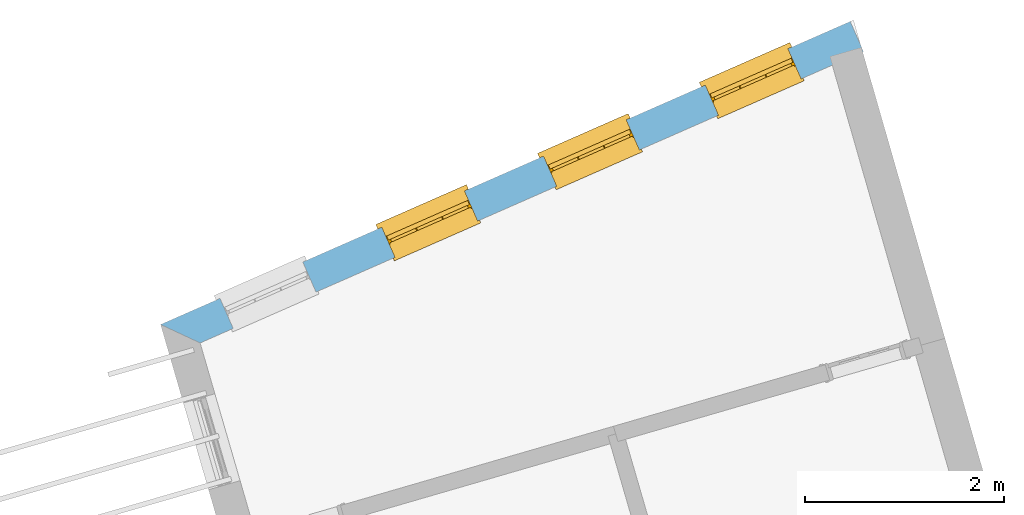
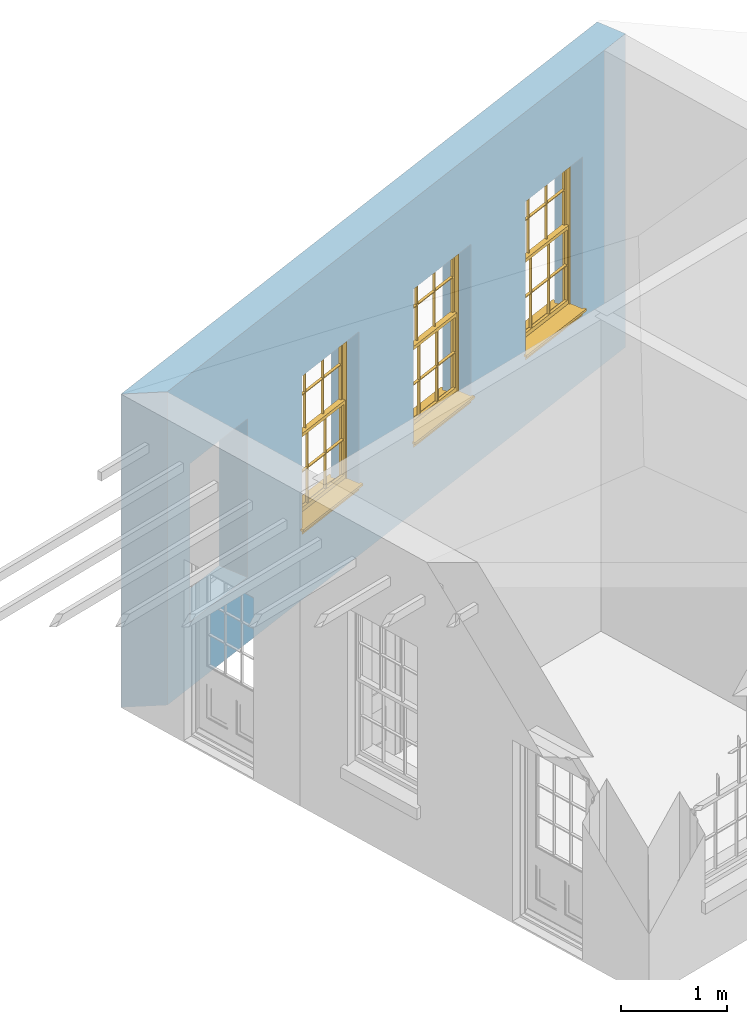
# One storey, part 6 of 10: 3 windows, 4 openings, plus 1 element that does not belong to this part.
"""IFC2X3 building model written with IfcOpenShell, lengths in metres."""

from ifc_helpers import new_model, si_unit, frame, origin, place, context, subcontext, project, spatial, polyline, outline, extrude, faceted_brep, material, layer, layer_set, layer_usage, element, fill, save


model = new_model("IFC2X3")

# Units and contexts
model_context = context("Model", 3, world=origin())
body_context = subcontext(model_context, "Body", "Model", "MODEL_VIEW")
ifc_project = project(units=[si_unit("PLANEANGLEUNIT", "RADIAN"), si_unit("MASSUNIT", "GRAM", prefix="KILO"), si_unit("FORCEUNIT", "NEWTON", prefix="KILO"), si_unit("LENGTHUNIT", "METRE")], contexts=[model_context])

# Site, building, storey
site_placement = place(None, origin())
site = spatial("IfcSite", under=ifc_project, at=site_placement, CompositionType="ELEMENT")
building_placement = place(None, origin())
building = spatial("IfcBuilding", under=site, at=building_placement, Name="Building plot-15", CompositionType="ELEMENT")
storey_placement = place(None, frame((0.0, 0.0, 11.05)))
storey = spatial("IfcBuildingStorey", under=building, at=storey_placement, Name="Floor 2", CompositionType="ELEMENT", Elevation=11.05)

# Wall, openings, windows
ifc_material = material(Name="Masonry")
ifc_layer = layer(ifc_material, 0.33, ventilated=False)
ifc_layer_set = layer_set([ifc_layer], Name="My Wall")
ifc_layer_usage = layer_usage(ifc_layer_set, "AXIS2", "NEGATIVE", 0.08)
wall_placement = place(storey_placement, origin())
wall = element("IfcWallStandardCase", 1, at=wall_placement, inside=storey, material=ifc_layer_usage, Name="exterior", context=body_context, shape_type="SweptSolid", body=[
    extrude(outline(polyline([(95.6723187451732, 60.4106615143609), (95.5395561949644, 60.7127775603797), (88.6036069877965, 57.6648285454347), (89.0011789339124, 57.4790809319541), (95.6723187451732, 60.4106615143609)])), origin(), (0.0, 0.0, 1.0), 3.6),
])
opening_1_placement = place(storey_placement, frame((0.0, 0.0, 0.75)))
opening_1 = element("IfcOpeningElement", 2, at=opening_1_placement, cuts=wall, Name="Opening", ObjectType="Opening", context=body_context, shape_type="SweptSolid", body=[
    extrude(outline(polyline([(94.9139268152625, 60.4378495880681), (94.0808189307863, 60.0717467980984), (94.2135814809951, 59.7696307520796), (95.0466893654713, 60.1357335420493), (94.9139268152625, 60.4378495880681)])), origin(), (0.0, 0.0, 1.0), 1.82),
])
opening_2_placement = place(storey_placement, frame((0.0, 0.0, 0.75)))
opening_2 = element("IfcOpeningElement", 3, at=opening_2_placement, cuts=wall, Name="Opening", ObjectType="Opening", context=body_context, shape_type="SweptSolid", body=[
    extrude(outline(polyline([(93.2873117562595, 59.7230462325794), (92.4542038717833, 59.3569434426097), (92.5869664219921, 59.0548273965908), (93.4200743064683, 59.4209301865605), (93.2873117562595, 59.7230462325794)])), origin(), (0.0, 0.0, 1.0), 1.82),
])
opening_3_placement = place(storey_placement, frame((0.0, 0.0, 0.75)))
opening_3 = element("IfcOpeningElement", 4, at=opening_3_placement, cuts=wall, Name="Opening", ObjectType="Opening", context=body_context, shape_type="SweptSolid", body=[
    extrude(outline(polyline([(91.6606966972566, 59.0082428770907), (90.8275888127803, 58.642140087121), (90.9603513629891, 58.3400240411021), (91.7934592474653, 58.7061268310718), (91.6606966972566, 59.0082428770907)])), origin(), (0.0, 0.0, 1.0), 1.82),
])
opening_4_placement = place(storey_placement, frame((0.0, 0.0, 0.75)))
element("IfcOpeningElement", 5, at=opening_4_placement, cuts=wall, Name="Opening", ObjectType="Opening", context=body_context, shape_type="SweptSolid", body=[
    extrude(outline(polyline([(90.0340816382536, 58.2934395216019), (89.2009737537774, 57.9273367316322), (89.3337363039862, 57.6252206856134), (90.1668441884623, 57.9913234755831), (90.0340816382536, 58.2934395216019)])), origin(), (0.0, 0.0, 1.0), 1.82),
])
window_1_placement = place(storey_placement, frame((95.0145045048146, 60.2089737956296, 0.75), z_axis=(0.0, 0.0, 1.0), x_axis=(-0.833107884476192, -0.366102789969688, 0.0)))
window_1 = element("IfcWindow", 6, at=window_1_placement, inside=storey, Name="circulation outside window", OverallHeight=1.82, OverallWidth=0.91, context=body_context, shape_type="Brep", held_by="IfcProductRepresentation", body=[
    faceted_brep([(0.033125, -0.105, 0.975209), (0.01, -0.105, 0.975209), (0.033125, -0.105, 1.376042), (0.876875, -0.105, 0.975209), (0.876875, -0.105, 1.376042), (0.9, -0.105, 0.975209), (0.876875, -0.105, 1.386042), (0.876875, -0.105, 1.786875), (0.9, -0.105, 1.81), (0.033125, -0.105, 1.786875), (0.033125, -0.105, 1.386042), (0.01, -0.105, 1.81), (0.876875, -0.135, 1.376042), (0.876875, -0.135, 0.975209), (0.9, -0.135, 0.937083), (0.033125, -0.135, 1.786875), (0.01, -0.135, 1.81), (0.033125, -0.135, 1.386042), (0.01, -0.135, 0.937083), (0.033125, -0.135, 0.975209), (0.033125, -0.135, 1.376042), (0.876875, -0.135, 1.786875), (0.876875, -0.135, 1.386042), (0.9, -0.135, 1.81), (0.033125, -0.105, 0.937083), (0.01, -0.105, 0.937083), (0.033125, -0.105, 0.53625), (0.876875, -0.105, 0.937083), (0.876875, -0.105, 0.53625), (0.9, -0.105, 0.937083), (0.876875, -0.105, 0.52625), (0.876875, -0.105, 0.125417), (0.9, -0.105, 0.077167), (0.033125, -0.105, 0.125417), (0.033125, -0.105, 0.52625), (0.01, -0.105, 0.077167), (-0.0425, -0.25, 0.01), (-0.0425, -0.3, 0.001667), (0.0, -0.25, 0.01), (0.9525, -0.25, 0.01), (0.91, -0.25, 0.01), (0.9525, -0.3, 0.001667), (-0.02, 0.08, 0.077167), (0.0, 0.08, 0.077167), (-0.02, 0.11, 0.077167), (0.0, -0.06, 0.077167), (0.01, -0.06, 0.077167), (0.91, -0.06, 0.077167), (0.91, 0.08, 0.077167), (0.9, -0.06, 0.077167), (0.93, 0.08, 0.077167), (0.93, 0.11, 0.077167), (0.01, -0.075, 0.975209), (0.9, -0.075, 0.975209), (0.876875, -0.075, 0.125417), (0.876875, -0.075, 0.52625), (0.9, -0.075, 0.077167), (0.876875, -0.075, 0.53625), (0.876875, -0.075, 0.937083), (0.033125, -0.075, 0.125417), (0.01, -0.075, 0.077167), (0.033125, -0.075, 0.52625), (0.033125, -0.075, 0.937083), (0.033125, -0.075, 0.53625), (-0.02, 0.08, 0.052167), (-0.02, 0.11, 0.052167), (0.93, 0.11, 0.052167), (0.93, 0.08, 0.052167), (0.91, 0.08, 0.052167), (0.0, 0.08, 0.052167), (0.91, -0.15, 0.026667), (0.0, -0.15, 0.026667), (-0.0425, -0.3, -0.123333), (0.9525, -0.3, -0.123333), (-0.0425, -0.25, -0.123333), (0.9525, -0.25, -0.123333), (0.01, -0.06, 1.81), (0.9, -0.06, 1.81), (0.0, -0.06, 1.82), (0.91, -0.06, 1.82), (0.01, -0.15, 0.077167), (0.9, -0.15, 0.077167), (0.592292, -0.105, 0.125417), (0.592292, -0.075, 0.125417), (0.317708, -0.075, 0.125417), (0.317708, -0.105, 0.125417), (0.592292, -0.105, 0.53625), (0.317708, -0.105, 0.53625), (0.317708, -0.105, 0.52625), (0.592292, -0.105, 0.52625), (0.592292, -0.075, 0.53625), (0.317708, -0.075, 0.53625), (0.592292, -0.135, 1.386042), (0.592292, -0.105, 1.386042), (0.317708, -0.105, 1.386042), (0.317708, -0.135, 1.386042), (0.317708, -0.135, 1.376042), (0.592292, -0.135, 1.376042), (0.317708, -0.105, 1.376042), (0.592292, -0.105, 1.376042), (0.602292, -0.135, 1.376042), (0.592292, -0.135, 0.975209), (0.602292, -0.135, 0.975209), (0.602292, -0.105, 0.975209), (0.592292, -0.105, 0.975209), (0.602292, -0.105, 1.376042), (0.602292, -0.075, 0.53625), (0.602292, -0.105, 0.53625), (0.317708, -0.075, 0.52625), (0.307708, -0.075, 0.125417), (0.307708, -0.075, 0.52625), (0.602292, -0.075, 0.52625), (0.602292, -0.075, 0.125417), (0.592292, -0.075, 0.52625), (0.307708, -0.075, 0.53625), (0.317708, -0.075, 0.937083), (0.307708, -0.075, 0.937083), (0.602292, -0.075, 0.937083), (0.592292, -0.075, 0.937083), (0.307708, -0.105, 0.52625), (0.307708, -0.105, 0.125417), (0.307708, -0.105, 0.53625), (0.307708, -0.105, 0.937083), (0.592292, -0.105, 0.937083), (0.317708, -0.105, 0.937083), (0.602292, -0.105, 0.937083), (0.602292, -0.105, 0.52625), (0.602292, -0.105, 0.125417), (0.307708, -0.135, 1.386042), (0.307708, -0.135, 1.376042), (0.307708, -0.135, 0.975209), (0.317708, -0.135, 0.975209), (0.317708, -0.135, 1.786875), (0.307708, -0.135, 1.786875), (0.602292, -0.135, 1.786875), (0.592292, -0.135, 1.786875), (0.602292, -0.135, 1.386042), (0.602292, -0.105, 1.386042), (0.307708, -0.105, 1.386042), (0.307708, -0.105, 1.786875), (0.317708, -0.105, 1.786875), (0.592292, -0.105, 1.786875), (0.602292, -0.105, 1.786875), (0.307708, -0.105, 1.376042), (0.317708, -0.105, 0.975209), (0.307708, -0.105, 0.975209), (0.91, -0.15, 1.82), (0.9, -0.15, 1.81), (0.01, -0.15, 1.81), (0.0, -0.15, 1.82), (0.91, -0.25, 0.0), (0.0, -0.25, 0.0), (0.91, 0.08, 0.0), (0.0, 0.08, 0.0)], [[[0, 1, 2]], [[3, 4, 5]], [[6, 7, 8]], [[9, 10, 11]], [[12, 13, 14]], [[15, 16, 17]], [[18, 19, 20]], [[21, 22, 23]], [[24, 25, 26]], [[27, 28, 29]], [[30, 31, 32]], [[33, 34, 35]], [[14, 27, 29]], [[25, 24, 18]], [[36, 37, 38]], [[39, 40, 41]], [[42, 43, 44]], [[45, 46, 43]], [[47, 48, 49]], [[50, 51, 48]], [[1, 0, 52]], [[5, 53, 3]], [[54, 55, 56]], [[57, 58, 53]], [[59, 60, 61]], [[62, 63, 52]], [[48, 43, 46, 49]], [[51, 44, 43, 48]], [[64, 42, 44, 65]], [[65, 44, 51, 66]], [[66, 51, 50, 67]], [[65, 66, 68, 69]], [[60, 56, 49, 46]], [[70, 71, 38, 40]], [[37, 41, 40, 38]], [[37, 72, 73, 41]], [[74, 75, 73, 72]], [[8, 11, 76, 77]], [[76, 78, 79, 77]], [[32, 35, 80, 81]], [[81, 80, 71, 70]], [[82, 83, 84, 85]], [[86, 87, 88, 89]], [[86, 90, 91, 87]], [[92, 93, 94, 95]], [[92, 95, 96, 97]], [[96, 98, 99, 97]], [[100, 97, 101, 102]], [[103, 104, 99, 105]], [[97, 99, 104, 101]], [[102, 103, 105, 100]], [[28, 57, 106, 107]], [[108, 84, 109, 110]], [[111, 112, 83, 113]], [[114, 110, 61, 63]], [[90, 113, 108, 91]], [[115, 91, 114, 116]], [[117, 106, 90, 118]], [[111, 106, 57, 55]], [[119, 110, 109, 120]], [[34, 61, 110, 119]], [[89, 113, 83, 82]], [[88, 108, 113, 89]], [[85, 84, 108, 88]], [[121, 114, 63, 26]], [[122, 116, 114, 121]], [[123, 118, 90, 86]], [[87, 91, 115, 124]], [[107, 106, 117, 125]], [[126, 111, 55, 30]], [[127, 112, 111, 126]], [[126, 30, 28, 107]], [[88, 119, 120, 85]], [[126, 89, 82, 127]], [[125, 123, 86, 107]], [[121, 26, 34, 119]], [[124, 122, 121, 87]], [[128, 17, 20, 129]], [[96, 129, 130, 131]], [[132, 133, 128, 95]], [[134, 135, 92, 136]], [[100, 12, 22, 136]], [[137, 6, 4, 105]], [[94, 138, 139, 140]], [[137, 93, 141, 142]], [[99, 98, 94, 93]], [[143, 2, 10, 138]], [[144, 145, 143, 98]], [[129, 143, 145, 130]], [[20, 2, 143, 129]], [[131, 144, 98, 96]], [[128, 138, 10, 17]], [[133, 139, 138, 128]], [[135, 141, 93, 92]], [[95, 94, 140, 132]], [[22, 6, 137, 136]], [[136, 137, 142, 134]], [[100, 105, 4, 12]], [[107, 86, 89, 126]], [[106, 111, 113, 90]], [[91, 108, 110, 114]], [[87, 121, 119, 88]], [[97, 100, 136, 92]], [[129, 96, 95, 128]], [[98, 143, 138, 94]], [[105, 99, 93, 137]], [[131, 101, 104, 144]], [[124, 115, 118, 123]], [[132, 140, 141, 135]], [[120, 109, 59, 33]], [[15, 9, 139, 133]], [[134, 142, 7, 21]], [[31, 54, 112, 127]], [[36, 74, 72, 37]], [[39, 41, 73, 75]], [[18, 14, 101, 131]], [[23, 16, 132, 135]], [[83, 56, 60, 84]], [[52, 53, 118, 115]], [[53, 52, 144, 104]], [[11, 8, 141, 140]], [[14, 18, 124, 123]], [[2, 1, 11, 10]], [[8, 5, 4, 6]], [[57, 53, 56, 55]], [[60, 52, 63, 61]], [[26, 25, 35, 34]], [[32, 29, 28, 30]], [[14, 23, 22, 12]], [[18, 20, 17, 16]], [[19, 0, 2, 20]], [[17, 10, 9, 15]], [[12, 4, 3, 13]], [[21, 7, 6, 22]], [[27, 58, 57, 28]], [[30, 55, 54, 31]], [[33, 59, 61, 34]], [[26, 63, 62, 24]], [[5, 8, 77, 53]], [[76, 11, 1, 52]], [[46, 45, 78, 76]], [[49, 77, 79, 47]], [[70, 146, 147, 81]], [[71, 80, 148, 149]], [[19, 130, 145, 0]], [[102, 13, 3, 103]], [[116, 122, 24, 62]], [[29, 32, 81, 14]], [[80, 35, 25, 18]], [[60, 46, 76, 52]], [[77, 49, 56, 53]], [[23, 14, 81, 147]], [[16, 148, 80, 18]], [[35, 85, 120]], [[120, 33, 35]], [[127, 82, 32]], [[32, 31, 127]], [[32, 82, 85, 35]], [[102, 101, 14]], [[14, 13, 102]], [[18, 131, 130]], [[130, 19, 18]], [[134, 21, 23]], [[23, 135, 134]], [[16, 15, 133]], [[133, 132, 16]], [[11, 140, 139]], [[139, 9, 11]], [[142, 141, 8]], [[8, 7, 142]], [[23, 147, 148, 16]], [[146, 149, 148, 147]], [[52, 115, 116]], [[116, 62, 52]], [[118, 53, 117]], [[58, 117, 53]], [[27, 125, 117, 58]], [[56, 83, 112]], [[112, 54, 56]], [[109, 84, 60]], [[60, 59, 109]], [[125, 27, 14]], [[14, 123, 125]], [[122, 124, 18]], [[18, 24, 122]], [[145, 144, 52]], [[52, 0, 145]], [[103, 3, 53]], [[53, 104, 103]], [[79, 78, 149, 146]], [[78, 45, 71, 149]], [[146, 70, 47, 79]], [[150, 75, 74, 151]], [[68, 66, 67]], [[48, 68, 67, 50]], [[69, 64, 65]], [[42, 64, 69, 43]], [[69, 68, 152, 153]], [[70, 68, 48, 47]], [[150, 152, 68, 70]], [[43, 69, 71, 45]], [[69, 153, 151, 71]], [[152, 150, 151, 153]], [[38, 151, 74, 36]], [[71, 151, 38]], [[39, 75, 150, 40]], [[40, 150, 70]]]),
])
fill(opening_1, window_1)
window_2_placement = place(storey_placement, frame((93.3878894458116, 59.4941704401409, 0.75), z_axis=(0.0, 0.0, 1.0), x_axis=(-0.833107884476206, -0.366102789969695, 0.0)))
window_2 = element("IfcWindow", 7, at=window_2_placement, inside=storey, Name="circulation outside window", OverallHeight=1.82, OverallWidth=0.91, context=body_context, shape_type="Brep", held_by="IfcProductRepresentation", body=[
    faceted_brep([(0.033125, -0.105, 0.975209), (0.01, -0.105, 0.975209), (0.033125, -0.105, 1.376042), (0.876875, -0.105, 0.975209), (0.876875, -0.105, 1.376042), (0.9, -0.105, 0.975209), (0.876875, -0.105, 1.386042), (0.876875, -0.105, 1.786875), (0.9, -0.105, 1.81), (0.033125, -0.105, 1.786875), (0.033125, -0.105, 1.386042), (0.01, -0.105, 1.81), (0.876875, -0.135, 1.376042), (0.876875, -0.135, 0.975209), (0.9, -0.135, 0.937083), (0.033125, -0.135, 1.786875), (0.01, -0.135, 1.81), (0.033125, -0.135, 1.386042), (0.01, -0.135, 0.937083), (0.033125, -0.135, 0.975209), (0.033125, -0.135, 1.376042), (0.876875, -0.135, 1.786875), (0.876875, -0.135, 1.386042), (0.9, -0.135, 1.81), (0.033125, -0.105, 0.937083), (0.01, -0.105, 0.937083), (0.033125, -0.105, 0.53625), (0.876875, -0.105, 0.937083), (0.876875, -0.105, 0.53625), (0.9, -0.105, 0.937083), (0.876875, -0.105, 0.52625), (0.876875, -0.105, 0.125417), (0.9, -0.105, 0.077167), (0.033125, -0.105, 0.125417), (0.033125, -0.105, 0.52625), (0.01, -0.105, 0.077167), (-0.0425, -0.25, 0.01), (-0.0425, -0.3, 0.001667), (0.0, -0.25, 0.01), (0.9525, -0.25, 0.01), (0.91, -0.25, 0.01), (0.9525, -0.3, 0.001667), (-0.02, 0.08, 0.077167), (0.0, 0.08, 0.077167), (-0.02, 0.11, 0.077167), (0.0, -0.06, 0.077167), (0.01, -0.06, 0.077167), (0.91, -0.06, 0.077167), (0.91, 0.08, 0.077167), (0.9, -0.06, 0.077167), (0.93, 0.08, 0.077167), (0.93, 0.11, 0.077167), (0.01, -0.075, 0.975209), (0.9, -0.075, 0.975209), (0.876875, -0.075, 0.125417), (0.876875, -0.075, 0.52625), (0.9, -0.075, 0.077167), (0.876875, -0.075, 0.53625), (0.876875, -0.075, 0.937083), (0.033125, -0.075, 0.125417), (0.01, -0.075, 0.077167), (0.033125, -0.075, 0.52625), (0.033125, -0.075, 0.937083), (0.033125, -0.075, 0.53625), (-0.02, 0.08, 0.052167), (-0.02, 0.11, 0.052167), (0.93, 0.11, 0.052167), (0.93, 0.08, 0.052167), (0.91, 0.08, 0.052167), (0.0, 0.08, 0.052167), (0.91, -0.15, 0.026667), (0.0, -0.15, 0.026667), (-0.0425, -0.3, -0.123333), (0.9525, -0.3, -0.123333), (-0.0425, -0.25, -0.123333), (0.9525, -0.25, -0.123333), (0.01, -0.06, 1.81), (0.9, -0.06, 1.81), (0.0, -0.06, 1.82), (0.91, -0.06, 1.82), (0.01, -0.15, 0.077167), (0.9, -0.15, 0.077167), (0.592292, -0.105, 0.125417), (0.592292, -0.075, 0.125417), (0.317708, -0.075, 0.125417), (0.317708, -0.105, 0.125417), (0.592292, -0.105, 0.53625), (0.317708, -0.105, 0.53625), (0.317708, -0.105, 0.52625), (0.592292, -0.105, 0.52625), (0.592292, -0.075, 0.53625), (0.317708, -0.075, 0.53625), (0.592292, -0.135, 1.386042), (0.592292, -0.105, 1.386042), (0.317708, -0.105, 1.386042), (0.317708, -0.135, 1.386042), (0.317708, -0.135, 1.376042), (0.592292, -0.135, 1.376042), (0.317708, -0.105, 1.376042), (0.592292, -0.105, 1.376042), (0.602292, -0.135, 1.376042), (0.592292, -0.135, 0.975209), (0.602292, -0.135, 0.975209), (0.602292, -0.105, 0.975209), (0.592292, -0.105, 0.975209), (0.602292, -0.105, 1.376042), (0.602292, -0.075, 0.53625), (0.602292, -0.105, 0.53625), (0.317708, -0.075, 0.52625), (0.307708, -0.075, 0.125417), (0.307708, -0.075, 0.52625), (0.602292, -0.075, 0.52625), (0.602292, -0.075, 0.125417), (0.592292, -0.075, 0.52625), (0.307708, -0.075, 0.53625), (0.317708, -0.075, 0.937083), (0.307708, -0.075, 0.937083), (0.602292, -0.075, 0.937083), (0.592292, -0.075, 0.937083), (0.307708, -0.105, 0.52625), (0.307708, -0.105, 0.125417), (0.307708, -0.105, 0.53625), (0.307708, -0.105, 0.937083), (0.592292, -0.105, 0.937083), (0.317708, -0.105, 0.937083), (0.602292, -0.105, 0.937083), (0.602292, -0.105, 0.52625), (0.602292, -0.105, 0.125417), (0.307708, -0.135, 1.386042), (0.307708, -0.135, 1.376042), (0.307708, -0.135, 0.975209), (0.317708, -0.135, 0.975209), (0.317708, -0.135, 1.786875), (0.307708, -0.135, 1.786875), (0.602292, -0.135, 1.786875), (0.592292, -0.135, 1.786875), (0.602292, -0.135, 1.386042), (0.602292, -0.105, 1.386042), (0.307708, -0.105, 1.386042), (0.307708, -0.105, 1.786875), (0.317708, -0.105, 1.786875), (0.592292, -0.105, 1.786875), (0.602292, -0.105, 1.786875), (0.307708, -0.105, 1.376042), (0.317708, -0.105, 0.975209), (0.307708, -0.105, 0.975209), (0.91, -0.15, 1.82), (0.9, -0.15, 1.81), (0.01, -0.15, 1.81), (0.0, -0.15, 1.82), (0.91, -0.25, 0.0), (0.0, -0.25, 0.0), (0.91, 0.08, 0.0), (0.0, 0.08, 0.0)], [[[0, 1, 2]], [[3, 4, 5]], [[6, 7, 8]], [[9, 10, 11]], [[12, 13, 14]], [[15, 16, 17]], [[18, 19, 20]], [[21, 22, 23]], [[24, 25, 26]], [[27, 28, 29]], [[30, 31, 32]], [[33, 34, 35]], [[14, 27, 29]], [[25, 24, 18]], [[36, 37, 38]], [[39, 40, 41]], [[42, 43, 44]], [[45, 46, 43]], [[47, 48, 49]], [[50, 51, 48]], [[1, 0, 52]], [[5, 53, 3]], [[54, 55, 56]], [[57, 58, 53]], [[59, 60, 61]], [[62, 63, 52]], [[48, 43, 46, 49]], [[51, 44, 43, 48]], [[64, 42, 44, 65]], [[65, 44, 51, 66]], [[66, 51, 50, 67]], [[65, 66, 68, 69]], [[60, 56, 49, 46]], [[70, 71, 38, 40]], [[37, 41, 40, 38]], [[37, 72, 73, 41]], [[74, 75, 73, 72]], [[8, 11, 76, 77]], [[76, 78, 79, 77]], [[32, 35, 80, 81]], [[81, 80, 71, 70]], [[82, 83, 84, 85]], [[86, 87, 88, 89]], [[86, 90, 91, 87]], [[92, 93, 94, 95]], [[92, 95, 96, 97]], [[96, 98, 99, 97]], [[100, 97, 101, 102]], [[103, 104, 99, 105]], [[97, 99, 104, 101]], [[102, 103, 105, 100]], [[28, 57, 106, 107]], [[108, 84, 109, 110]], [[111, 112, 83, 113]], [[114, 110, 61, 63]], [[90, 113, 108, 91]], [[115, 91, 114, 116]], [[117, 106, 90, 118]], [[111, 106, 57, 55]], [[119, 110, 109, 120]], [[34, 61, 110, 119]], [[89, 113, 83, 82]], [[88, 108, 113, 89]], [[85, 84, 108, 88]], [[121, 114, 63, 26]], [[122, 116, 114, 121]], [[123, 118, 90, 86]], [[87, 91, 115, 124]], [[107, 106, 117, 125]], [[126, 111, 55, 30]], [[127, 112, 111, 126]], [[126, 30, 28, 107]], [[88, 119, 120, 85]], [[126, 89, 82, 127]], [[125, 123, 86, 107]], [[121, 26, 34, 119]], [[124, 122, 121, 87]], [[128, 17, 20, 129]], [[96, 129, 130, 131]], [[132, 133, 128, 95]], [[134, 135, 92, 136]], [[100, 12, 22, 136]], [[137, 6, 4, 105]], [[94, 138, 139, 140]], [[137, 93, 141, 142]], [[99, 98, 94, 93]], [[143, 2, 10, 138]], [[144, 145, 143, 98]], [[129, 143, 145, 130]], [[20, 2, 143, 129]], [[131, 144, 98, 96]], [[128, 138, 10, 17]], [[133, 139, 138, 128]], [[135, 141, 93, 92]], [[95, 94, 140, 132]], [[22, 6, 137, 136]], [[136, 137, 142, 134]], [[100, 105, 4, 12]], [[107, 86, 89, 126]], [[106, 111, 113, 90]], [[91, 108, 110, 114]], [[87, 121, 119, 88]], [[97, 100, 136, 92]], [[129, 96, 95, 128]], [[98, 143, 138, 94]], [[105, 99, 93, 137]], [[131, 101, 104, 144]], [[124, 115, 118, 123]], [[132, 140, 141, 135]], [[120, 109, 59, 33]], [[15, 9, 139, 133]], [[134, 142, 7, 21]], [[31, 54, 112, 127]], [[36, 74, 72, 37]], [[39, 41, 73, 75]], [[18, 14, 101, 131]], [[23, 16, 132, 135]], [[83, 56, 60, 84]], [[52, 53, 118, 115]], [[53, 52, 144, 104]], [[11, 8, 141, 140]], [[14, 18, 124, 123]], [[2, 1, 11, 10]], [[8, 5, 4, 6]], [[57, 53, 56, 55]], [[60, 52, 63, 61]], [[26, 25, 35, 34]], [[32, 29, 28, 30]], [[14, 23, 22, 12]], [[18, 20, 17, 16]], [[19, 0, 2, 20]], [[17, 10, 9, 15]], [[12, 4, 3, 13]], [[21, 7, 6, 22]], [[27, 58, 57, 28]], [[30, 55, 54, 31]], [[33, 59, 61, 34]], [[26, 63, 62, 24]], [[5, 8, 77, 53]], [[76, 11, 1, 52]], [[46, 45, 78, 76]], [[49, 77, 79, 47]], [[70, 146, 147, 81]], [[71, 80, 148, 149]], [[19, 130, 145, 0]], [[102, 13, 3, 103]], [[116, 122, 24, 62]], [[29, 32, 81, 14]], [[80, 35, 25, 18]], [[60, 46, 76, 52]], [[77, 49, 56, 53]], [[23, 14, 81, 147]], [[16, 148, 80, 18]], [[35, 85, 120]], [[120, 33, 35]], [[127, 82, 32]], [[32, 31, 127]], [[32, 82, 85, 35]], [[102, 101, 14]], [[14, 13, 102]], [[18, 131, 130]], [[130, 19, 18]], [[134, 21, 23]], [[23, 135, 134]], [[16, 15, 133]], [[133, 132, 16]], [[11, 140, 139]], [[139, 9, 11]], [[142, 141, 8]], [[8, 7, 142]], [[23, 147, 148, 16]], [[146, 149, 148, 147]], [[52, 115, 116]], [[116, 62, 52]], [[118, 53, 117]], [[58, 117, 53]], [[27, 125, 117, 58]], [[56, 83, 112]], [[112, 54, 56]], [[109, 84, 60]], [[60, 59, 109]], [[125, 27, 14]], [[14, 123, 125]], [[122, 124, 18]], [[18, 24, 122]], [[145, 144, 52]], [[52, 0, 145]], [[103, 3, 53]], [[53, 104, 103]], [[79, 78, 149, 146]], [[78, 45, 71, 149]], [[146, 70, 47, 79]], [[150, 75, 74, 151]], [[68, 66, 67]], [[48, 68, 67, 50]], [[69, 64, 65]], [[42, 64, 69, 43]], [[69, 68, 152, 153]], [[70, 68, 48, 47]], [[150, 152, 68, 70]], [[43, 69, 71, 45]], [[69, 153, 151, 71]], [[152, 150, 151, 153]], [[38, 151, 74, 36]], [[71, 151, 38]], [[39, 75, 150, 40]], [[40, 150, 70]]]),
])
fill(opening_2, window_2)
window_3_placement = place(storey_placement, frame((91.7612743868087, 58.7793670846521, 0.75), z_axis=(0.0, 0.0, 1.0), x_axis=(-0.833107884476206, -0.366102789969695, 0.0)))
window_3 = element("IfcWindow", 8, at=window_3_placement, inside=storey, Name="circulation outside window", OverallHeight=1.82, OverallWidth=0.91, context=body_context, shape_type="Brep", held_by="IfcProductRepresentation", body=[
    faceted_brep([(0.033125, -0.105, 0.975209), (0.01, -0.105, 0.975209), (0.033125, -0.105, 1.376042), (0.876875, -0.105, 0.975209), (0.876875, -0.105, 1.376042), (0.9, -0.105, 0.975209), (0.876875, -0.105, 1.386042), (0.876875, -0.105, 1.786875), (0.9, -0.105, 1.81), (0.033125, -0.105, 1.786875), (0.033125, -0.105, 1.386042), (0.01, -0.105, 1.81), (0.876875, -0.135, 1.376042), (0.876875, -0.135, 0.975209), (0.9, -0.135, 0.937083), (0.033125, -0.135, 1.786875), (0.01, -0.135, 1.81), (0.033125, -0.135, 1.386042), (0.01, -0.135, 0.937083), (0.033125, -0.135, 0.975209), (0.033125, -0.135, 1.376042), (0.876875, -0.135, 1.786875), (0.876875, -0.135, 1.386042), (0.9, -0.135, 1.81), (0.033125, -0.105, 0.937083), (0.01, -0.105, 0.937083), (0.033125, -0.105, 0.53625), (0.876875, -0.105, 0.937083), (0.876875, -0.105, 0.53625), (0.9, -0.105, 0.937083), (0.876875, -0.105, 0.52625), (0.876875, -0.105, 0.125417), (0.9, -0.105, 0.077167), (0.033125, -0.105, 0.125417), (0.033125, -0.105, 0.52625), (0.01, -0.105, 0.077167), (-0.0425, -0.25, 0.01), (-0.0425, -0.3, 0.001667), (0.0, -0.25, 0.01), (0.9525, -0.25, 0.01), (0.91, -0.25, 0.01), (0.9525, -0.3, 0.001667), (-0.02, 0.08, 0.077167), (0.0, 0.08, 0.077167), (-0.02, 0.11, 0.077167), (0.0, -0.06, 0.077167), (0.01, -0.06, 0.077167), (0.91, -0.06, 0.077167), (0.91, 0.08, 0.077167), (0.9, -0.06, 0.077167), (0.93, 0.08, 0.077167), (0.93, 0.11, 0.077167), (0.01, -0.075, 0.975209), (0.9, -0.075, 0.975209), (0.876875, -0.075, 0.125417), (0.876875, -0.075, 0.52625), (0.9, -0.075, 0.077167), (0.876875, -0.075, 0.53625), (0.876875, -0.075, 0.937083), (0.033125, -0.075, 0.125417), (0.01, -0.075, 0.077167), (0.033125, -0.075, 0.52625), (0.033125, -0.075, 0.937083), (0.033125, -0.075, 0.53625), (-0.02, 0.08, 0.052167), (-0.02, 0.11, 0.052167), (0.93, 0.11, 0.052167), (0.93, 0.08, 0.052167), (0.91, 0.08, 0.052167), (0.0, 0.08, 0.052167), (0.91, -0.15, 0.026667), (0.0, -0.15, 0.026667), (-0.0425, -0.3, -0.123333), (0.9525, -0.3, -0.123333), (-0.0425, -0.25, -0.123333), (0.9525, -0.25, -0.123333), (0.01, -0.06, 1.81), (0.9, -0.06, 1.81), (0.0, -0.06, 1.82), (0.91, -0.06, 1.82), (0.01, -0.15, 0.077167), (0.9, -0.15, 0.077167), (0.592292, -0.105, 0.125417), (0.592292, -0.075, 0.125417), (0.317708, -0.075, 0.125417), (0.317708, -0.105, 0.125417), (0.592292, -0.105, 0.53625), (0.317708, -0.105, 0.53625), (0.317708, -0.105, 0.52625), (0.592292, -0.105, 0.52625), (0.592292, -0.075, 0.53625), (0.317708, -0.075, 0.53625), (0.592292, -0.135, 1.386042), (0.592292, -0.105, 1.386042), (0.317708, -0.105, 1.386042), (0.317708, -0.135, 1.386042), (0.317708, -0.135, 1.376042), (0.592292, -0.135, 1.376042), (0.317708, -0.105, 1.376042), (0.592292, -0.105, 1.376042), (0.602292, -0.135, 1.376042), (0.592292, -0.135, 0.975209), (0.602292, -0.135, 0.975209), (0.602292, -0.105, 0.975209), (0.592292, -0.105, 0.975209), (0.602292, -0.105, 1.376042), (0.602292, -0.075, 0.53625), (0.602292, -0.105, 0.53625), (0.317708, -0.075, 0.52625), (0.307708, -0.075, 0.125417), (0.307708, -0.075, 0.52625), (0.602292, -0.075, 0.52625), (0.602292, -0.075, 0.125417), (0.592292, -0.075, 0.52625), (0.307708, -0.075, 0.53625), (0.317708, -0.075, 0.937083), (0.307708, -0.075, 0.937083), (0.602292, -0.075, 0.937083), (0.592292, -0.075, 0.937083), (0.307708, -0.105, 0.52625), (0.307708, -0.105, 0.125417), (0.307708, -0.105, 0.53625), (0.307708, -0.105, 0.937083), (0.592292, -0.105, 0.937083), (0.317708, -0.105, 0.937083), (0.602292, -0.105, 0.937083), (0.602292, -0.105, 0.52625), (0.602292, -0.105, 0.125417), (0.307708, -0.135, 1.386042), (0.307708, -0.135, 1.376042), (0.307708, -0.135, 0.975209), (0.317708, -0.135, 0.975209), (0.317708, -0.135, 1.786875), (0.307708, -0.135, 1.786875), (0.602292, -0.135, 1.786875), (0.592292, -0.135, 1.786875), (0.602292, -0.135, 1.386042), (0.602292, -0.105, 1.386042), (0.307708, -0.105, 1.386042), (0.307708, -0.105, 1.786875), (0.317708, -0.105, 1.786875), (0.592292, -0.105, 1.786875), (0.602292, -0.105, 1.786875), (0.307708, -0.105, 1.376042), (0.317708, -0.105, 0.975209), (0.307708, -0.105, 0.975209), (0.91, -0.15, 1.82), (0.9, -0.15, 1.81), (0.01, -0.15, 1.81), (0.0, -0.15, 1.82), (0.91, -0.25, 0.0), (0.0, -0.25, 0.0), (0.91, 0.08, 0.0), (0.0, 0.08, 0.0)], [[[0, 1, 2]], [[3, 4, 5]], [[6, 7, 8]], [[9, 10, 11]], [[12, 13, 14]], [[15, 16, 17]], [[18, 19, 20]], [[21, 22, 23]], [[24, 25, 26]], [[27, 28, 29]], [[30, 31, 32]], [[33, 34, 35]], [[14, 27, 29]], [[25, 24, 18]], [[36, 37, 38]], [[39, 40, 41]], [[42, 43, 44]], [[45, 46, 43]], [[47, 48, 49]], [[50, 51, 48]], [[1, 0, 52]], [[5, 53, 3]], [[54, 55, 56]], [[57, 58, 53]], [[59, 60, 61]], [[62, 63, 52]], [[48, 43, 46, 49]], [[51, 44, 43, 48]], [[64, 42, 44, 65]], [[65, 44, 51, 66]], [[66, 51, 50, 67]], [[65, 66, 68, 69]], [[60, 56, 49, 46]], [[70, 71, 38, 40]], [[37, 41, 40, 38]], [[37, 72, 73, 41]], [[74, 75, 73, 72]], [[8, 11, 76, 77]], [[76, 78, 79, 77]], [[32, 35, 80, 81]], [[81, 80, 71, 70]], [[82, 83, 84, 85]], [[86, 87, 88, 89]], [[86, 90, 91, 87]], [[92, 93, 94, 95]], [[92, 95, 96, 97]], [[96, 98, 99, 97]], [[100, 97, 101, 102]], [[103, 104, 99, 105]], [[97, 99, 104, 101]], [[102, 103, 105, 100]], [[28, 57, 106, 107]], [[108, 84, 109, 110]], [[111, 112, 83, 113]], [[114, 110, 61, 63]], [[90, 113, 108, 91]], [[115, 91, 114, 116]], [[117, 106, 90, 118]], [[111, 106, 57, 55]], [[119, 110, 109, 120]], [[34, 61, 110, 119]], [[89, 113, 83, 82]], [[88, 108, 113, 89]], [[85, 84, 108, 88]], [[121, 114, 63, 26]], [[122, 116, 114, 121]], [[123, 118, 90, 86]], [[87, 91, 115, 124]], [[107, 106, 117, 125]], [[126, 111, 55, 30]], [[127, 112, 111, 126]], [[126, 30, 28, 107]], [[88, 119, 120, 85]], [[126, 89, 82, 127]], [[125, 123, 86, 107]], [[121, 26, 34, 119]], [[124, 122, 121, 87]], [[128, 17, 20, 129]], [[96, 129, 130, 131]], [[132, 133, 128, 95]], [[134, 135, 92, 136]], [[100, 12, 22, 136]], [[137, 6, 4, 105]], [[94, 138, 139, 140]], [[137, 93, 141, 142]], [[99, 98, 94, 93]], [[143, 2, 10, 138]], [[144, 145, 143, 98]], [[129, 143, 145, 130]], [[20, 2, 143, 129]], [[131, 144, 98, 96]], [[128, 138, 10, 17]], [[133, 139, 138, 128]], [[135, 141, 93, 92]], [[95, 94, 140, 132]], [[22, 6, 137, 136]], [[136, 137, 142, 134]], [[100, 105, 4, 12]], [[107, 86, 89, 126]], [[106, 111, 113, 90]], [[91, 108, 110, 114]], [[87, 121, 119, 88]], [[97, 100, 136, 92]], [[129, 96, 95, 128]], [[98, 143, 138, 94]], [[105, 99, 93, 137]], [[131, 101, 104, 144]], [[124, 115, 118, 123]], [[132, 140, 141, 135]], [[120, 109, 59, 33]], [[15, 9, 139, 133]], [[134, 142, 7, 21]], [[31, 54, 112, 127]], [[36, 74, 72, 37]], [[39, 41, 73, 75]], [[18, 14, 101, 131]], [[23, 16, 132, 135]], [[83, 56, 60, 84]], [[52, 53, 118, 115]], [[53, 52, 144, 104]], [[11, 8, 141, 140]], [[14, 18, 124, 123]], [[2, 1, 11, 10]], [[8, 5, 4, 6]], [[57, 53, 56, 55]], [[60, 52, 63, 61]], [[26, 25, 35, 34]], [[32, 29, 28, 30]], [[14, 23, 22, 12]], [[18, 20, 17, 16]], [[19, 0, 2, 20]], [[17, 10, 9, 15]], [[12, 4, 3, 13]], [[21, 7, 6, 22]], [[27, 58, 57, 28]], [[30, 55, 54, 31]], [[33, 59, 61, 34]], [[26, 63, 62, 24]], [[5, 8, 77, 53]], [[76, 11, 1, 52]], [[46, 45, 78, 76]], [[49, 77, 79, 47]], [[70, 146, 147, 81]], [[71, 80, 148, 149]], [[19, 130, 145, 0]], [[102, 13, 3, 103]], [[116, 122, 24, 62]], [[29, 32, 81, 14]], [[80, 35, 25, 18]], [[60, 46, 76, 52]], [[77, 49, 56, 53]], [[23, 14, 81, 147]], [[16, 148, 80, 18]], [[35, 85, 120]], [[120, 33, 35]], [[127, 82, 32]], [[32, 31, 127]], [[32, 82, 85, 35]], [[102, 101, 14]], [[14, 13, 102]], [[18, 131, 130]], [[130, 19, 18]], [[134, 21, 23]], [[23, 135, 134]], [[16, 15, 133]], [[133, 132, 16]], [[11, 140, 139]], [[139, 9, 11]], [[142, 141, 8]], [[8, 7, 142]], [[23, 147, 148, 16]], [[146, 149, 148, 147]], [[52, 115, 116]], [[116, 62, 52]], [[118, 53, 117]], [[58, 117, 53]], [[27, 125, 117, 58]], [[56, 83, 112]], [[112, 54, 56]], [[109, 84, 60]], [[60, 59, 109]], [[125, 27, 14]], [[14, 123, 125]], [[122, 124, 18]], [[18, 24, 122]], [[145, 144, 52]], [[52, 0, 145]], [[103, 3, 53]], [[53, 104, 103]], [[79, 78, 149, 146]], [[78, 45, 71, 149]], [[146, 70, 47, 79]], [[150, 75, 74, 151]], [[68, 66, 67]], [[48, 68, 67, 50]], [[69, 64, 65]], [[42, 64, 69, 43]], [[69, 68, 152, 153]], [[70, 68, 48, 47]], [[150, 152, 68, 70]], [[43, 69, 71, 45]], [[69, 153, 151, 71]], [[152, 150, 151, 153]], [[38, 151, 74, 36]], [[71, 151, 38]], [[39, 75, 150, 40]], [[40, 150, 70]]]),
])
fill(opening_3, window_3)

save(model, "model.ifc")
